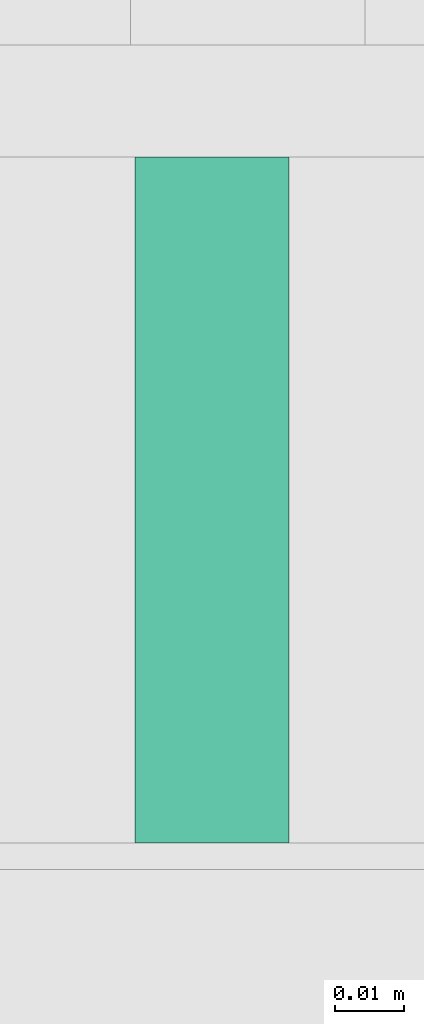
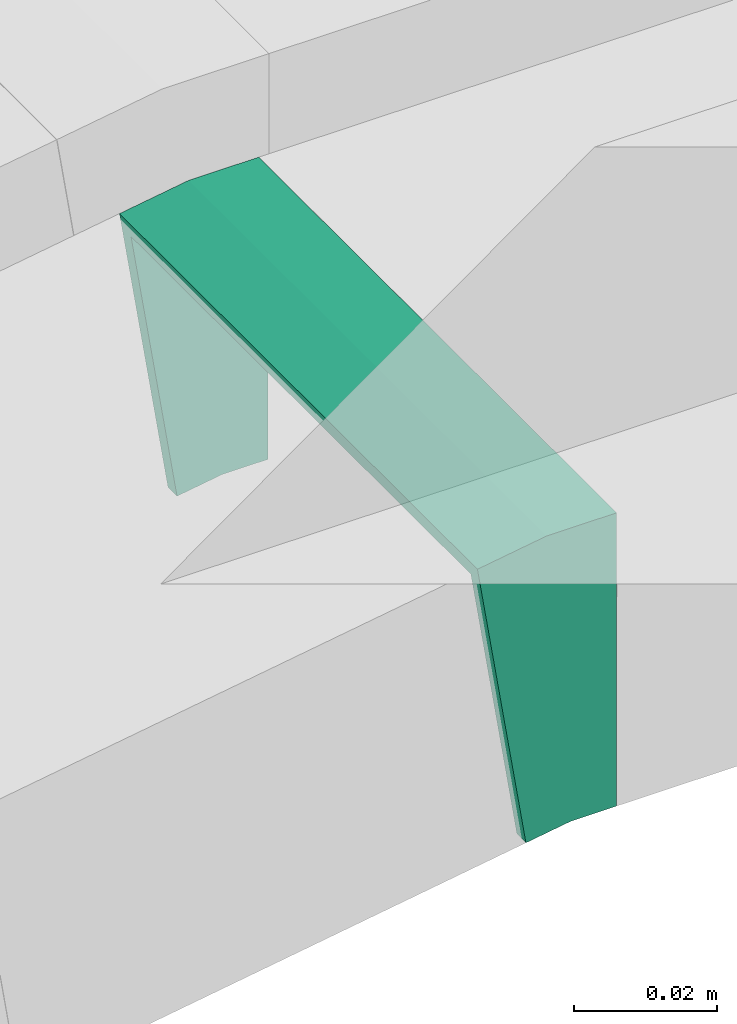
# One storey, part 28 of 28: 1 flow fitting.
"""IFC2X3 building model written with IfcOpenShell, lengths in millimetres."""

from ifc_helpers import new_model, entity, si_unit, converted_unit, derived_unit, direction, frame, origin, place, context, subcontext, project, spatial, faceted_brep, source, transform, mapped, material, type_object, type_shapes, element, save


model = new_model("IFC2X3")

# Units and contexts
model_context = context("Model", 3, precision=0.01, world=origin(), true_north=direction((6.12303176911189e-17, 1.0)))
body_context = subcontext(model_context, "Body", "Model", "MODEL_VIEW")
ifc_project = project(units=[si_unit("LENGTHUNIT", "METRE", prefix="MILLI"), si_unit("AREAUNIT", "SQUARE_METRE"), si_unit("VOLUMEUNIT", "CUBIC_METRE"), converted_unit("PLANEANGLEUNIT", "DEGREE", entity("IfcRatioMeasure", 0.0174532925199433), si_unit("PLANEANGLEUNIT", "RADIAN"), dimensions=[0, 0, 0, 0, 0, 0, 0]), si_unit("MASSUNIT", "GRAM", prefix="KILO"), derived_unit("MASSDENSITYUNIT", [(si_unit("MASSUNIT", "GRAM", prefix="KILO"), 1), (si_unit("LENGTHUNIT", "METRE"), -3)]), derived_unit("MOMENTOFINERTIAUNIT", [(si_unit("LENGTHUNIT", "METRE"), 4)]), si_unit("TIMEUNIT", "SECOND"), si_unit("FREQUENCYUNIT", "HERTZ"), si_unit("THERMODYNAMICTEMPERATUREUNIT", "DEGREE_CELSIUS"), derived_unit("THERMALTRANSMITTANCEUNIT", [(si_unit("MASSUNIT", "GRAM", prefix="KILO"), 1), (si_unit("THERMODYNAMICTEMPERATUREUNIT", "KELVIN"), -1), (si_unit("TIMEUNIT", "SECOND"), -3)]), derived_unit("VOLUMETRICFLOWRATEUNIT", [(si_unit("LENGTHUNIT", "METRE"), 3), (si_unit("TIMEUNIT", "SECOND"), -1)]), derived_unit("MASSFLOWRATEUNIT", [(si_unit("MASSUNIT", "GRAM", prefix="KILO"), 1), (si_unit("TIMEUNIT", "SECOND"), -1)]), derived_unit("ROTATIONALFREQUENCYUNIT", [(si_unit("TIMEUNIT", "SECOND"), -1)]), si_unit("ELECTRICCURRENTUNIT", "AMPERE"), si_unit("ELECTRICVOLTAGEUNIT", "VOLT"), si_unit("POWERUNIT", "WATT"), si_unit("FORCEUNIT", "NEWTON", prefix="KILO"), si_unit("ILLUMINANCEUNIT", "LUX"), si_unit("LUMINOUSFLUXUNIT", "LUMEN"), si_unit("LUMINOUSINTENSITYUNIT", "CANDELA"), derived_unit("USERDEFINED", [(si_unit("MASSUNIT", "GRAM", prefix="KILO"), -1), (si_unit("LENGTHUNIT", "METRE"), -2), (si_unit("TIMEUNIT", "SECOND"), 3), (si_unit("LUMINOUSFLUXUNIT", "LUMEN"), 1)]), derived_unit("LINEARVELOCITYUNIT", [(si_unit("LENGTHUNIT", "METRE"), 1), (si_unit("TIMEUNIT", "SECOND"), -1)]), si_unit("PRESSUREUNIT", "PASCAL"), derived_unit("USERDEFINED", [(si_unit("LENGTHUNIT", "METRE"), -2), (si_unit("MASSUNIT", "GRAM", prefix="KILO"), 1), (si_unit("TIMEUNIT", "SECOND"), -2)]), derived_unit("LINEARFORCEUNIT", [(si_unit("MASSUNIT", "GRAM", prefix="KILO"), 1), (si_unit("LENGTHUNIT", "METRE"), 1), (si_unit("TIMEUNIT", "SECOND"), -2), (si_unit("LENGTHUNIT", "METRE"), -1)]), derived_unit("PLANARFORCEUNIT", [(si_unit("MASSUNIT", "GRAM", prefix="KILO"), 1), (si_unit("LENGTHUNIT", "METRE"), 1), (si_unit("TIMEUNIT", "SECOND"), -2), (si_unit("LENGTHUNIT", "METRE"), -2)])], contexts=[model_context])

# Site, building, storey
site_placement = place(None, origin())
site = spatial("IfcSite", under=ifc_project, at=site_placement, CompositionType="ELEMENT")
building_placement = place(site_placement, origin())
building = spatial("IfcBuilding", under=site, at=building_placement, CompositionType="ELEMENT")
storey_placement = place(building_placement, frame((0.0, 0.0, 4200.0)))
storey = spatial("IfcBuildingStorey", under=building, at=storey_placement, CompositionType="ELEMENT", Elevation=4200.0)

# Flow fitting
ifc_material = material()
cable_carrier_fitting_type = type_object("IfcCableCarrierFittingType", PredefinedType="NOTDEFINED", material=ifc_material)
shared_shape = source(origin(), body_context, "Body", "Brep", [
    faceted_brep([(-9.33, -25.0, 50.0), (-9.33, 25.0, 50.0), (-9.33, 25.0, 47.46), (-9.33, -22.46, 47.46), (-9.33, -22.46, -47.46), (-9.33, 25.0, -47.46), (-9.33, 25.0, -50.0), (-9.33, -25.0, -50.0), (13.13, -23.23, 50.0), (13.13, -23.23, -50.0), (5.3, 26.15, -50.0), (5.3, 26.15, -47.46), (12.73, -20.72, -47.46), (12.73, -20.72, 47.46), (5.3, 26.15, 47.46), (5.3, 26.15, 50.0), (1.97, -25.0, 50.0), (-1.97, 25.0, 50.0), (-1.97, 25.0, 47.46), (1.77, -22.46, 47.46), (1.77, -22.46, -47.46), (-1.97, 25.0, -47.46), (-1.97, 25.0, -50.0), (1.97, -25.0, -50.0)], [[[0, 1, 2, 3, 4, 5, 6, 7]], [[8, 9, 10, 11, 12, 13, 14, 15]], [[1, 0, 16, 8, 15, 17]], [[2, 1, 17, 18]], [[3, 2, 18, 14, 13, 19]], [[4, 3, 19, 20]], [[5, 4, 20, 12, 11, 21]], [[6, 5, 21, 22]], [[7, 6, 22, 10, 9, 23]], [[0, 7, 23, 16]], [[18, 17, 15, 14]], [[20, 19, 13, 12]], [[22, 21, 11, 10]], [[16, 23, 9, 8]]]),
])
type_shapes(cable_carrier_fitting_type, [shared_shape])
flow_fitting_placement = place(storey_placement, frame((64353.65, 8597.45, 2708.3), z_axis=(0.0, 1.0, 0.0), x_axis=(0.98768834059514, 0.0, 0.156434465040214)))
element("IfcFlowFitting", 1, at=flow_fitting_placement, inside=storey, type_object=cable_carrier_fitting_type, material=ifc_material, context=body_context, shape_type="MappedRepresentation", body=[
    mapped(shared_shape, transform((0.0, 0.0, 0.0), scale=1.0)),
])

save(model, "model.ifc")
